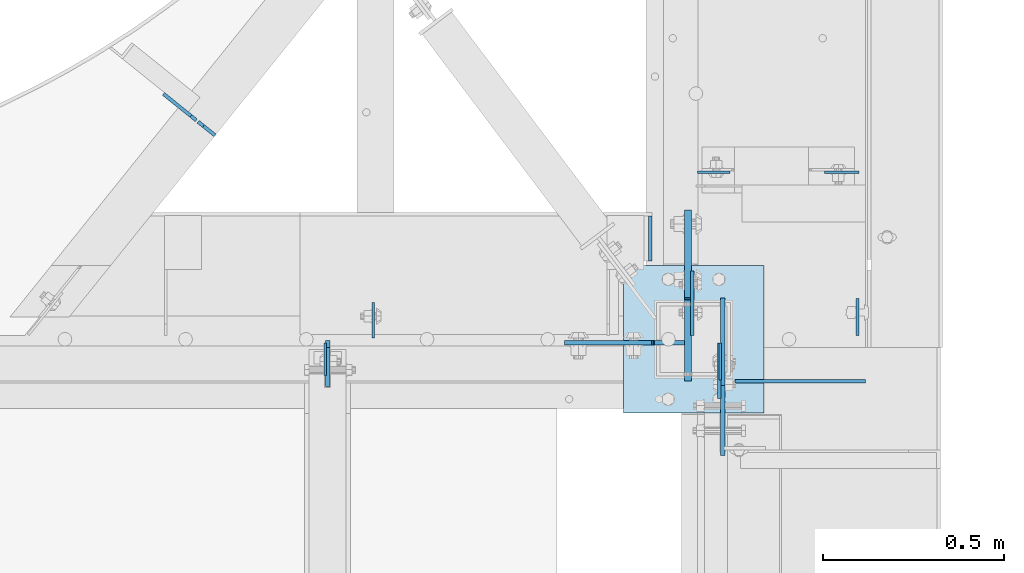
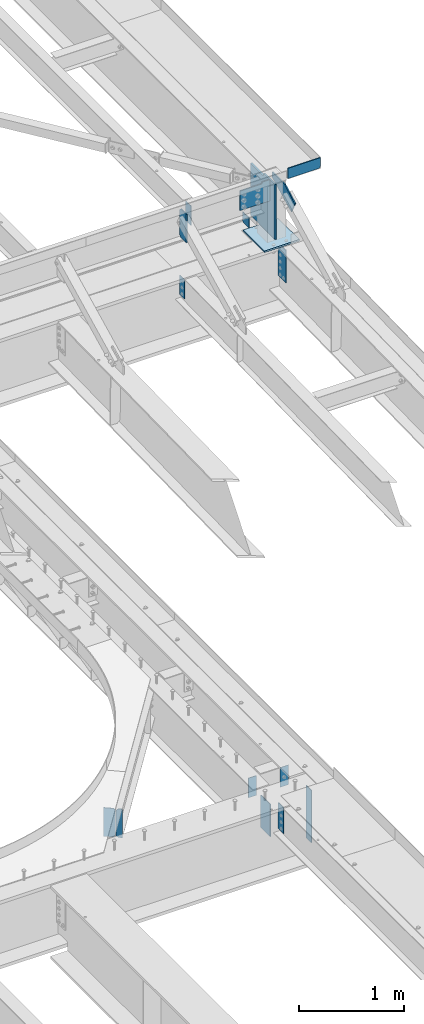
# One storey, part 1677 of 1763: 17 plates, 8 elements without a shape of their own.
"""IFC2X3 building model written with IfcOpenShell, lengths in millimetres."""

from ifc_helpers import new_model, si_unit, frame, origin_with_axes, place, context, subcontext, project, spatial, faceted_brep, material, type_object, element, aggregate, save


model = new_model("IFC2X3")

# Units and contexts
model_context = context("Model", 3, precision=1e-05, world=origin_with_axes())
body_context = subcontext(model_context, "Body", "Model", "MODEL_VIEW")
ifc_project = project(units=[si_unit("LENGTHUNIT", "METRE", prefix="MILLI"), si_unit("AREAUNIT", "SQUARE_METRE"), si_unit("VOLUMEUNIT", "CUBIC_METRE"), si_unit("MASSUNIT", "GRAM", prefix="KILO"), si_unit("TIMEUNIT", "SECOND"), si_unit("PLANEANGLEUNIT", "RADIAN"), si_unit("SOLIDANGLEUNIT", "STERADIAN"), si_unit("THERMODYNAMICTEMPERATUREUNIT", "DEGREE_CELSIUS"), si_unit("LUMINOUSINTENSITYUNIT", "LUMEN")], contexts=[model_context])

# Site, building, storey
site_placement = place(None, origin_with_axes())
site = spatial("IfcSite", under=ifc_project, at=site_placement, CompositionType="ELEMENT")
building_placement = place(site_placement, origin_with_axes())
building = spatial("IfcBuilding", under=site, at=building_placement, Name="Undefined", CompositionType="ELEMENT")
storey_placement = place(building_placement, origin_with_axes())
storey = spatial("IfcBuildingStorey", under=building, at=storey_placement, Name="Undefined", CompositionType="ELEMENT", Elevation=0.0)

# Assembly, plate
assembly_1_placement = place(storey_placement, origin_with_axes())
assembly_1 = element("IfcElementAssembly", 1, at=assembly_1_placement, inside=storey, Name="BEAM", AssemblyPlace="NOTDEFINED", PredefinedType="RIGID_FRAME")
ifc_material_1 = material(Name="STEEL/A36")
plate_type_1 = type_object("IfcPlateType", PredefinedType="NOTDEFINED")
plate_1_placement = place(assembly_1_placement, frame((-21555.7396174483, 52004.9125, 12452.35), z_axis=(0.0, 0.0, 1.0), x_axis=(1.0, 0.0, 0.0)))
plate_1 = element("IfcPlate", 2, at=plate_1_placement, type_object=plate_type_1, material=ifc_material_1, Name="PLATE", context=body_context, shape_type="Brep", body=[
    faceted_brep([(0.0, -4.76249999999982, 0.0), (3.8198777474463e-11, -4.76249999978609, 120.649999999834), (3.45607986673713e-11, 4.76250000024447, 120.649999999841), (0.0, 4.76249999999982, 0.0), (358.774993896484, -4.76249999999709, 120.650001525879), (358.774993896484, 4.76249999999709, 120.650001525879), (358.774993896484, -4.76249999999709, 19.0499992370605), (358.774993896484, 4.76249999999709, 19.0499992370605), (339.724994659424, -4.76249999999709, 0.0), (339.724994659424, 4.76249999999709, 0.0)], [[[0, 1, 2, 3]], [[1, 4, 5, 2]], [[4, 6, 7, 5]], [[6, 8, 9, 7]], [[8, 0, 3, 9]], [[5, 7, 9, 3, 2]], [[8, 6, 4, 1, 0]]]),
])
aggregate(assembly_1, [plate_1])

assembly_2_placement = place(storey_placement, origin_with_axes())
assembly_2 = element("IfcElementAssembly", 3, at=assembly_2_placement, inside=storey, Name="BEAM", AssemblyPlace="NOTDEFINED", PredefinedType="RIGID_FRAME")
plate_type_2 = type_object("IfcPlateType", PredefinedType="NOTDEFINED")
plate_2_placement = place(assembly_2_placement, frame((-21599.7593943556, 52110.4812502128, 11658.8961266487), z_axis=(0.0, -1.0, 0.0), x_axis=(0.0, 0.0, -1.0)))
plate_2 = element("IfcPlate", 4, at=plate_2_placement, type_object=plate_type_2, material=ifc_material_1, Name="PLATE", context=body_context, shape_type="Brep", body=[
    faceted_brep([(0.0, -4.76249999999982, 0.0), (-3.05175672110636e-06, -4.7625000002663, 152.399993896484), (-3.05175490211695e-06, 4.76249999972788, 152.399993896484), (0.0, 4.76249999999982, 0.0), (381.0, -4.76250000000073, 152.399993896484), (381.0, 4.76250000000073, 152.399993896484), (381.0, -4.76250000000073, 0.0), (381.0, 4.76250000000073, 0.0)], [[[0, 1, 2, 3]], [[1, 4, 5, 2]], [[4, 6, 7, 5]], [[6, 0, 3, 7]], [[5, 7, 3, 2]], [[6, 4, 1, 0]]]),
])

assembly_3_placement = place(storey_placement, origin_with_axes())
assembly_3 = element("IfcElementAssembly", 5, at=assembly_3_placement, inside=storey, Name="BEAM", AssemblyPlace="NOTDEFINED", PredefinedType="RIGID_FRAME")
plate_type_3 = type_object("IfcPlateType", PredefinedType="NOTDEFINED")
plate_3_placement = place(assembly_3_placement, frame((-21213.6333674484, 52581.1925415639, 5143.5), z_axis=(-1.0, 0.0, 0.0), x_axis=(0.0, 0.0, -1.0)))
plate_3 = element("IfcPlate", 6, at=plate_3_placement, type_object=plate_type_3, material=ifc_material_1, Name="PLATE", context=body_context, shape_type="Brep", body=[
    faceted_brep([(1.81898940354586e-12, -3.17500000000291, 0.0), (0.0, -3.17499999999927, 95.25), (0.0, 3.17499999999927, 95.25), (-1.81898940354586e-12, 3.17499999997381, 0.0), (228.600006103516, -3.17500000000291, 95.25), (228.600006103516, 3.17500000000291, 95.25), (228.600006103516, -3.17500000001019, -7.27595761418343e-12), (228.600006103516, 3.17499999999563, -7.27595761418343e-12)], [[[0, 1, 2, 3]], [[1, 4, 5, 2]], [[4, 6, 7, 5]], [[6, 0, 3, 7]], [[5, 7, 3, 2]], [[6, 4, 1, 0]]]),
])
aggregate(assembly_3, [plate_3])

# Assembly, plates
assembly_4_placement = place(storey_placement, origin_with_axes())
assembly_4 = element("IfcElementAssembly", 7, at=assembly_4_placement, inside=storey, Name="BEAM", AssemblyPlace="NOTDEFINED", PredefinedType="RIGID_FRAME")
plate_type_4 = type_object("IfcPlateType", PredefinedType="NOTDEFINED")
plate_4_placement = place(assembly_4_placement, frame((-22988.3167411551, 52682.4717733071, 4852.9875), z_axis=(0.0, 0.0, 1.0), x_axis=(-0.779362269487869, 0.626573581392256, 0.0)))
plate_4 = element("IfcPlate", 8, at=plate_4_placement, type_object=plate_type_4, material=ifc_material_1, Name="PLATE", context=body_context, shape_type="Brep", body=[
    faceted_brep([(0.0, -4.76249999999982, 0.0), (0.0, -4.76250000001528, 333.375), (2.18278728425503e-11, 4.76250000000073, 333.375), (0.0, 4.76249999999982, 0.0), (41.2750015259371, -4.76250000006985, 333.375), (41.2750015259444, 4.76249999995343, 333.375), (60.3250007630195, -4.76250000009168, 314.325000762939), (60.325000763034, 4.76249999992433, 314.325000762939), (60.3250007630195, -4.76250000009168, 19.0499992370605), (60.325000763034, 4.76249999992433, 19.0499992370605), (41.2750015259371, -4.76250000006985, 0.0), (41.2750015259444, 4.76249999995343, 0.0)], [[[0, 1, 2, 3]], [[1, 4, 5, 2]], [[4, 6, 7, 5]], [[6, 8, 9, 7]], [[8, 10, 11, 9]], [[10, 0, 3, 11]], [[5, 7, 9, 11, 3, 2]], [[10, 8, 6, 4, 1, 0]]]),
])
plate_type_5 = type_object("IfcPlateType", PredefinedType="NOTDEFINED")
plate_5_placement = place(assembly_4_placement, frame((-23040.2807204733, 52724.2485668467, 4852.9875), z_axis=(0.0, 0.0, 1.0), x_axis=(-0.779362269487869, 0.626573581392256, 0.0)))
plate_5 = element("IfcPlate", 9, at=plate_5_placement, type_object=plate_type_5, material=ifc_material_1, Name="PLATE", context=body_context, shape_type="Brep", body=[
    faceted_brep([(6.96272763889283e-08, -4.76249999999709, 19.0499992370605), (-7.27595761418343e-12, -4.76250000000073, 314.325000762939), (7.27595761418343e-12, 4.76250000000437, 314.325000762939), (6.96454662829638e-08, 4.76249999999709, 19.0499992370605), (19.0499992370824, -4.76250000002983, 333.375), (19.0499992370969, 4.76249999998254, 333.375), (115.887496948388, -4.76250000015716, 333.375), (115.887496948395, 4.76249999985885, 333.375), (115.887496948388, -4.76250000015716, 0.0), (115.887496948395, 4.76249999985885, 0.0), (19.0499992370533, -4.76249999996799, -2.09183781407773e-11), (19.0499992370678, 4.76250000003347, -2.09183781407773e-11)], [[[0, 1, 2, 3]], [[1, 4, 5, 2]], [[4, 6, 7, 5]], [[6, 8, 9, 7]], [[8, 10, 11, 9]], [[10, 0, 3, 11]], [[5, 7, 9, 11, 3, 2]], [[10, 8, 6, 4, 1, 0]]]),
])
aggregate(assembly_4, [plate_4, plate_5])

# Assembly, plate
assembly_5_placement = place(storey_placement, origin_with_axes())
assembly_5 = element("IfcElementAssembly", 10, at=assembly_5_placement, inside=storey, Name="BEAM", AssemblyPlace="NOTDEFINED", PredefinedType="RIGID_FRAME")
plate_type_6 = type_object("IfcPlateType", PredefinedType="NOTDEFINED")
plate_6_placement = place(assembly_5_placement, frame((-21596.5812736984, 52110.48125, 5124.45), z_axis=(0.0, -1.0, 0.0), x_axis=(0.0, 0.0, -1.0)))
plate_6 = element("IfcPlate", 11, at=plate_6_placement, type_object=plate_type_6, material=ifc_material_1, Name="PLATE", context=body_context, shape_type="Brep", body=[
    faceted_brep([(0.0, -3.96900000000096, 0.0), (-1.18234311230481e-11, -3.96900000000096, 101.599998474121), (-1.18234311230481e-11, 3.96900000000096, 101.599998474121), (0.0, 3.96900000000096, 0.0), (304.799987792969, -3.96900000000096, 101.599998474121), (304.799987792969, 3.96900000000096, 101.599998474121), (304.799987792969, -3.96900000000096, -3.63797880709171e-11), (304.799987792969, 3.96900000000096, -3.63797880709171e-11)], [[[0, 1, 2, 3]], [[1, 4, 5, 2]], [[4, 6, 7, 5]], [[6, 0, 3, 7]], [[5, 7, 3, 2]], [[6, 4, 1, 0]]]),
])

# Plate
plate_type_7 = type_object("IfcPlateType", PredefinedType="NOTDEFINED")
plate_7_placement = place(assembly_2_placement, frame((-22684.8122736984, 52110.4812502128, 11658.8961266475), z_axis=(0.0, -1.0, 0.0), x_axis=(0.0, 0.0, -1.0)))
plate_7 = element("IfcPlate", 12, at=plate_7_placement, type_object=plate_type_7, material=ifc_material_1, Name="PLATE", context=body_context, shape_type="Brep", body=[
    faceted_brep([(1.81898940354586e-12, -3.17500000000291, 0.0), (0.0, -3.17499999999927, 88.9000015258789), (0.0, 3.17499999999927, 88.9000015258789), (-1.81898940354586e-12, 3.17499999997381, 0.0), (228.600006103516, -3.17499999999927, 88.9000015258789), (228.600006103516, 3.17499999999927, 88.9000015258789), (228.600006103516, -3.17500000001019, -7.27595761418343e-12), (228.600006103516, 3.17499999999563, -7.27595761418343e-12)], [[[0, 1, 2, 3]], [[1, 4, 5, 2]], [[4, 6, 7, 5]], [[6, 0, 3, 7]], [[5, 7, 3, 2]], [[6, 4, 1, 0]]]),
])

# Assembly, plate
assembly_6_placement = place(storey_placement, origin_with_axes())
assembly_6 = element("IfcElementAssembly", 13, at=assembly_6_placement, inside=storey, Name="BEAM", AssemblyPlace="NOTDEFINED", PredefinedType="RIGID_FRAME")
plate_8_placement = place(assembly_6_placement, frame((-21658.9271174484, 52581.1925415639, 5143.5), z_axis=(1.0, 0.0, 0.0), x_axis=(0.0, 0.0, -1.0)))
plate_8 = element("IfcPlate", 14, at=plate_8_placement, type_object=plate_type_7, material=ifc_material_1, Name="PLATE", context=body_context, shape_type="Brep", body=[
    faceted_brep([(1.81898940354586e-12, -3.17500000000291, 0.0), (0.0, -3.17499999999927, 88.9000015258789), (0.0, 3.17499999999927, 88.9000015258789), (-1.81898940354586e-12, 3.17499999997381, 0.0), (228.600006103516, -3.17499999999927, 88.9000015258789), (228.600006103516, 3.17499999999927, 88.9000015258789), (228.600006103516, -3.17500000001019, -7.27595761418343e-12), (228.600006103516, 3.17499999999563, -7.27595761418343e-12)], [[[0, 1, 2, 3]], [[1, 4, 5, 2]], [[4, 6, 7, 5]], [[6, 0, 3, 7]], [[5, 7, 3, 2]], [[6, 4, 1, 0]]]),
])
aggregate(assembly_6, [plate_8])

assembly_7_placement = place(storey_placement, origin_with_axes())
assembly_7 = element("IfcElementAssembly", 15, at=assembly_7_placement, inside=storey, Name="BEAM", AssemblyPlace="NOTDEFINED", PredefinedType="RIGID_FRAME")
plate_type_8 = type_object("IfcPlateType", PredefinedType="NOTDEFINED")
plate_9_placement = place(assembly_7_placement, frame((-22678.4622736984, 51990.625, 12106.275), z_axis=(0.0, 0.0, 1.0), x_axis=(0.0, 1.0, 0.0)))
plate_9 = element("IfcPlate", 16, at=plate_9_placement, type_object=plate_type_8, material=ifc_material_1, Name="PLATE", context=body_context, shape_type="Brep", body=[
    faceted_brep([(0.0, -6.34999999999491, 1.45519152283669e-11), (0.0, -6.34999999999854, 330.200012207031), (0.0, 6.34999999999854, 330.200012207031), (0.0, 6.34999999999491, -2.91038304567337e-11), (107.950000762939, -6.34999999999854, 330.200012207031), (107.950000762939, 6.34999999999854, 330.200012207031), (127.0, -6.34999999999854, 311.150012969971), (127.0, 6.34999999999854, 311.150012969971), (127.0, -6.34999999999854, 19.0499992370605), (127.0, 6.34999999999854, 19.0499992370605), (107.950000762939, -6.34999999999854, 0.0), (107.950000762939, 6.34999999999854, 0.0)], [[[0, 1, 2, 3]], [[1, 4, 5, 2]], [[4, 6, 7, 5]], [[6, 8, 9, 7]], [[8, 10, 11, 9]], [[10, 0, 3, 11]], [[5, 7, 9, 11, 3, 2]], [[10, 8, 6, 4, 1, 0]]]),
])

assembly_8_placement = place(storey_placement, origin_with_axes())
assembly_8 = element("IfcElementAssembly", 17, at=assembly_8_placement, inside=storey, Name="COLUMN", AssemblyPlace="NOTDEFINED", PredefinedType="RIGID_FRAME")
plate_type_9 = type_object("IfcPlateType", PredefinedType="NOTDEFINED")
plate_10_placement = place(assembly_8_placement, frame((-21589.4406443556, 52235.0999999997, 12341.7708442777), z_axis=(0.0, -1.0, 0.0), x_axis=(0.0, 0.0, 1.0)))
plate_10 = element("IfcPlate", 18, at=plate_10_placement, type_object=plate_type_9, material=ifc_material_1, Name="PLATE", context=body_context, shape_type="Brep", body=[
    faceted_brep([(0.0, -6.34999999999491, 1.45519152283669e-11), (-183.125732421875, -6.34999999999854, 366.25146484375), (-183.125732421875, 6.34999999999854, 366.25146484375), (0.0, 6.34999999999491, -2.91038304567337e-11), (-46.8150367736816, -6.34999999999854, 434.406829833984), (-46.8150367736816, 6.34999999999854, 434.406829833984), (62.4383811950684, -6.34999999999854, 241.300003051758), (62.4383811950684, 6.34999999999854, 241.300003051758), (62.4383811950684, -6.34999999999854, 0.0), (62.4383811950684, 6.34999999999854, 0.0)], [[[0, 1, 2, 3]], [[1, 4, 5, 2]], [[4, 6, 7, 5]], [[6, 8, 9, 7]], [[8, 0, 3, 9]], [[5, 7, 9, 3, 2]], [[8, 6, 4, 1, 0]]]),
])

# Plate
plate_type_10 = type_object("IfcPlateType", PredefinedType="NOTDEFINED")
plate_11_placement = place(assembly_5_placement, frame((-21218.3958674484, 52131.11875, 5118.1), z_axis=(0.0, 1.0, 0.0), x_axis=(0.0, 0.0, -1.0)))
plate_11 = element("IfcPlate", 19, at=plate_11_placement, type_object=plate_type_10, material=ifc_material_1, Name="PLATE", context=body_context, shape_type="Brep", body=[
    faceted_brep([(0.0, -4.76249999999982, 0.0), (1.45519152283669e-11, -4.76250000000448, 101.60001373291), (0.0, 4.76250000000243, 101.60001373291), (0.0, 4.76249999999982, 0.0), (609.599975585938, -4.76250000000073, 101.599998474121), (609.599975585938, 4.76250000000073, 101.599998474121), (609.599975585938, -4.76250000000073, 0.0), (609.599975585938, 4.76250000000073, 0.0)], [[[0, 1, 2, 3]], [[1, 4, 5, 2]], [[4, 6, 7, 5]], [[6, 0, 3, 7]], [[5, 7, 3, 2]], [[6, 4, 1, 0]]]),
])

plate_type_11 = type_object("IfcPlateType", PredefinedType="NOTDEFINED")
plate_12_placement = place(assembly_7_placement, frame((-22552.6796174484, 52123.975, 12407.9), z_axis=(0.0, 1.0, 0.0), x_axis=(0.0, 0.0, -1.0)))
plate_12 = element("IfcPlate", 20, at=plate_12_placement, type_object=plate_type_11, material=ifc_material_1, Name="PLATE", context=body_context, shape_type="Brep", body=[
    faceted_brep([(1.81898940354586e-12, -3.17500000000291, 0.0), (-2.52839527092874e-10, -3.17500000000001, 98.4250000002357), (4.17785486206412e-08, 3.17500000000001, 98.425000000243), (-1.81898940354586e-12, 3.17499999997381, 0.0), (228.600006103516, -3.17499999999927, 98.4250030517578), (228.600006103516, 3.17499999999927, 98.4250030517578), (228.600006103516, -3.17500000001019, -7.27595761418343e-12), (228.600006103516, 3.17499999999563, -7.27595761418343e-12)], [[[0, 1, 2, 3]], [[1, 4, 5, 2]], [[4, 6, 7, 5]], [[6, 0, 3, 7]], [[5, 7, 3, 2]], [[6, 4, 1, 0]]]),
])

aggregate(assembly_7, [plate_9, plate_12])

plate_type_12 = type_object("IfcPlateType", PredefinedType="NOTDEFINED")
plate_13_placement = place(assembly_8_placement, frame((-21863.7146176612, 51917.5999969482, 11757.0249917654), z_axis=(0.0, 1.0, 0.0), x_axis=(1.0, 0.0, 0.0)))
plate_13 = element("IfcPlate", 21, at=plate_13_placement, type_object=plate_type_12, material=ifc_material_1, Name="PLATE", context=body_context, shape_type="Brep", body=[
    faceted_brep([(0.0, -9.52500000000146, 0.0), (0.0, -9.52499999999964, 406.399993896484), (0.0, 9.52499999999964, 406.399993896484), (0.0, 9.52500000000146, 0.0), (387.350006103516, -9.52499999999964, 406.399993896484), (387.350006103516, 9.52499999999964, 406.399993896484), (387.350006103516, -9.52499999999964, 0.0), (387.350006103516, 9.52499999999964, 0.0)], [[[0, 1, 2, 3]], [[1, 4, 5, 2]], [[4, 6, 7, 5]], [[6, 0, 3, 7]], [[5, 7, 3, 2]], [[6, 4, 1, 0]]]),
])

ifc_material_2 = material(Name="STEEL/A572-50")
plate_type_13 = type_object("IfcPlateType", PredefinedType="NOTDEFINED")
plate_14_placement = place(assembly_8_placement, frame((-21784.3396174484, 52111.275, 12426.95), z_axis=(0.0, 0.0, -1.0), x_axis=(1.0, 0.0, 0.0)))
plate_14 = element("IfcPlate", 22, at=plate_14_placement, type_object=plate_type_13, material=ifc_material_2, Name="PLATE", context=body_context, shape_type="Brep", body=[
    faceted_brep([(-241.300003051758, -6.34999999999854, 19.0500000000011), (-241.300003051758, 6.34999999999854, 19.0500000000011), (-6.34999980925932, 6.34999999999854, 19.0500000000011), (-6.34999980925932, -6.34999999999854, 19.0500000000011), (-1.48992029121291, 6.34999999999854, 18.0832700774135), (-1.48992029121291, -6.34999999999854, 18.0832700774135), (2.63025617694075, 6.34999999999854, 15.330256176936), (2.63025617694075, -6.34999999999854, 15.330256176936), (5.38327007741827, 6.34999999999854, 11.2100797087824), (5.38327007741827, -6.34999999999854, 11.2100797087824), (6.35000000000582, -6.34999999999854, 6.35000019073595), (6.35000000000582, 6.34999999999854, 6.35000019073595), (6.35000000000582, 6.35000000000036, 0.0), (6.34999990463257, -6.35000000000291, 0.0), (-241.300003051758, -6.34999999999854, 247.649993896484), (88.9000015258789, -6.34999999999854, 247.649993896484), (88.9000015258789, 6.34999999999854, 247.649993896484), (-241.300003051758, 6.34999999999854, 247.649993896484), (88.9000015258789, -6.34999999999854, 0.0), (88.9000015258789, 6.34999999999854, 0.0)], [[[0, 1, 2, 3]], [[3, 2, 4, 5]], [[5, 4, 6, 7]], [[7, 6, 8, 9]], [[10, 11, 12, 13]], [[9, 8, 11, 10]], [[14, 15, 16, 17]], [[15, 18, 19, 16]], [[19, 18, 13, 12]], [[6, 4, 2, 1, 17, 16, 19, 12, 11, 8]], [[14, 17, 1, 0]], [[18, 15, 14, 0, 3, 5, 7, 9, 10, 13]]]),
])

plate_type_14 = type_object("IfcPlateType", PredefinedType="NOTDEFINED")
plate_15_placement = place(assembly_8_placement, frame((-21685.9146174483, 52235.1, 12426.95), z_axis=(0.0, 0.0, -1.0), x_axis=(0.0, -1.0, 0.0)))
plate_15 = element("IfcPlate", 23, at=plate_15_placement, type_object=plate_type_14, material=ifc_material_2, Name="PLATE", context=body_context, shape_type="Brep", body=[
    faceted_brep([(-241.300003051758, -9.52500000000146, 31.75), (-241.300003051758, 9.52500000000146, 31.75), (-6.34999981028523, 9.52500000000146, 31.75), (-6.34999981028523, -9.52500000000146, 31.75), (-1.48992029223882, 9.52500000000146, 30.7832700774125), (-1.48992029223882, -9.52500000000146, 30.7832700774125), (2.63025617591484, 9.52500000000146, 28.0302561769349), (2.63025617591484, -9.52500000000146, 28.0302561769349), (5.38327007638873, 9.52500000000146, 23.9100797087813), (5.38327007638873, -9.52500000000146, 23.9100797087813), (6.34999999897991, -9.52500000000146, 19.0500001907349), (6.34999999897991, 9.52500000000146, 19.0500001907349), (6.34999999897991, 9.52500000000146, 0.0), (6.34999999897991, -9.52500000000146, 0.0), (-241.300003051758, -9.52500000000146, 641.349975585938), (228.600006103516, -9.52500000000146, 641.349975585938), (228.600006103516, 9.52500000000146, 641.349975585938), (-241.300003051758, 9.52500000000146, 641.349975585938), (228.600006103516, -9.52500000000146, 0.0), (228.600006103516, 9.52500000000146, 0.0)], [[[0, 1, 2, 3]], [[3, 2, 4, 5]], [[5, 4, 6, 7]], [[7, 6, 8, 9]], [[10, 11, 12, 13]], [[9, 8, 11, 10]], [[14, 15, 16, 17]], [[15, 18, 19, 16]], [[19, 18, 13, 12]], [[6, 4, 2, 1, 17, 16, 19, 12, 11, 8]], [[14, 17, 1, 0]], [[18, 15, 14, 0, 3, 5, 7, 9, 10, 13]]]),
])

aggregate(assembly_8, [plate_10, plate_13, plate_14, plate_15])

plate_type_15 = type_object("IfcPlateType", PredefinedType="NOTDEFINED")
plate_16_placement = place(assembly_2_placement, frame((-21789.1022736984, 52460.5250002128, 11757.0249917654), z_axis=(0.0, 0.0, 1.0), x_axis=(0.0, -1.0, 0.0)))
plate_16 = element("IfcPlate", 24, at=plate_16_placement, type_object=plate_type_15, material=ifc_material_1, Name="PLATE", context=body_context, shape_type="Brep", body=[
    faceted_brep([(6.96272763889283e-08, -4.76249999999709, 19.0499992370605), (0.0, -4.76249999983884, 117.474999999904), (0.0, 4.76250000013351, 117.474999999919), (6.96454662829638e-08, 4.76249999999709, 19.0499992370605), (123.824996948242, -4.76250000000073, 117.474998474121), (123.824996948242, 4.76250000000073, 117.474998474121), (123.824996948242, -4.76250000000073, 0.0), (123.824996948242, 4.76250000000073, 0.0), (19.0499992370533, -4.76249999996799, -2.09183781407773e-11), (19.0499992370678, 4.76250000003347, -2.09183781407773e-11)], [[[0, 1, 2, 3]], [[1, 4, 5, 2]], [[4, 6, 7, 5]], [[6, 8, 9, 7]], [[8, 0, 3, 9]], [[5, 7, 9, 3, 2]], [[8, 6, 4, 1, 0]]]),
])

aggregate(assembly_2, [plate_2, plate_16, plate_7])

plate_type_16 = type_object("IfcPlateType", PredefinedType="NOTDEFINED")
plate_17_placement = place(assembly_5_placement, frame((-21673.2146174484, 52131.11875, 5118.1), z_axis=(0.0, 1.0, 0.0), x_axis=(0.0, 0.0, -1.0)))
plate_17 = element("IfcPlate", 25, at=plate_17_placement, type_object=plate_type_16, material=ifc_material_1, Name="PLATE", context=body_context, shape_type="Brep", body=[
    faceted_brep([(0.0, -4.76249999999982, 0.0), (0.0, -4.76249999999709, 177.800003051758), (0.0, 4.76249999999709, 177.800003051758), (0.0, 4.76249999999982, 0.0), (381.0, -4.76249999999709, 177.800003051758), (381.0, 4.76249999999709, 177.800003051758), (381.0, -4.76250000000073, 0.0), (381.0, 4.76250000000073, 0.0)], [[[0, 1, 2, 3]], [[1, 4, 5, 2]], [[4, 6, 7, 5]], [[6, 0, 3, 7]], [[5, 7, 3, 2]], [[6, 4, 1, 0]]]),
])

aggregate(assembly_5, [plate_17, plate_11, plate_6])

save(model, "model.ifc")
